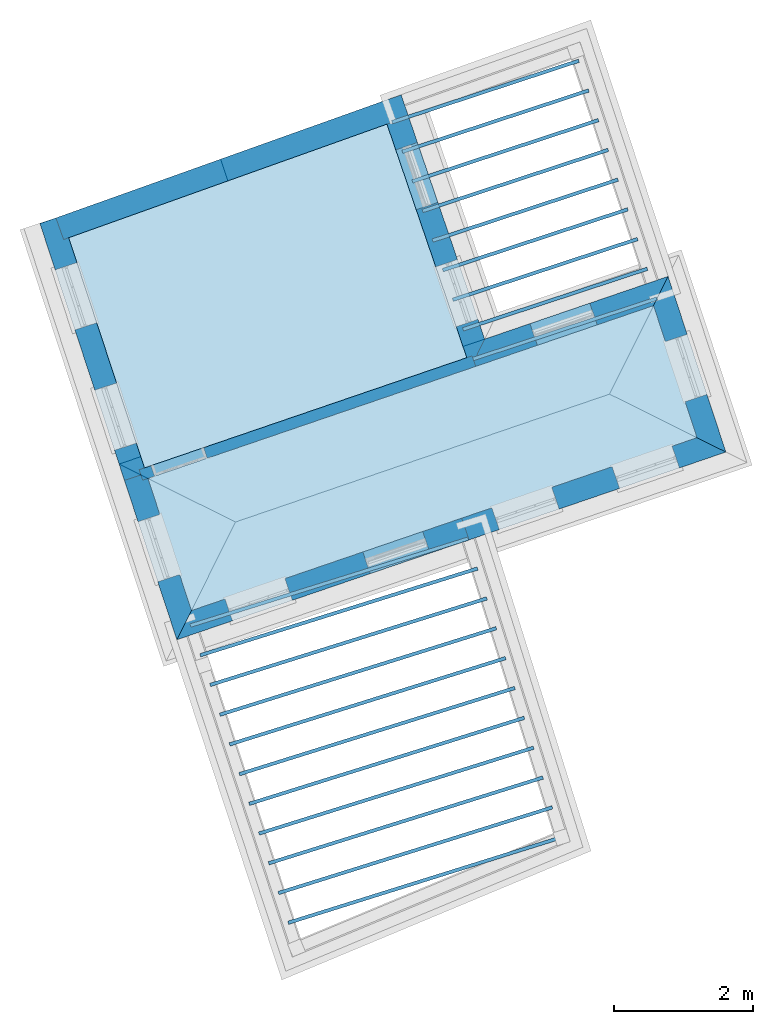
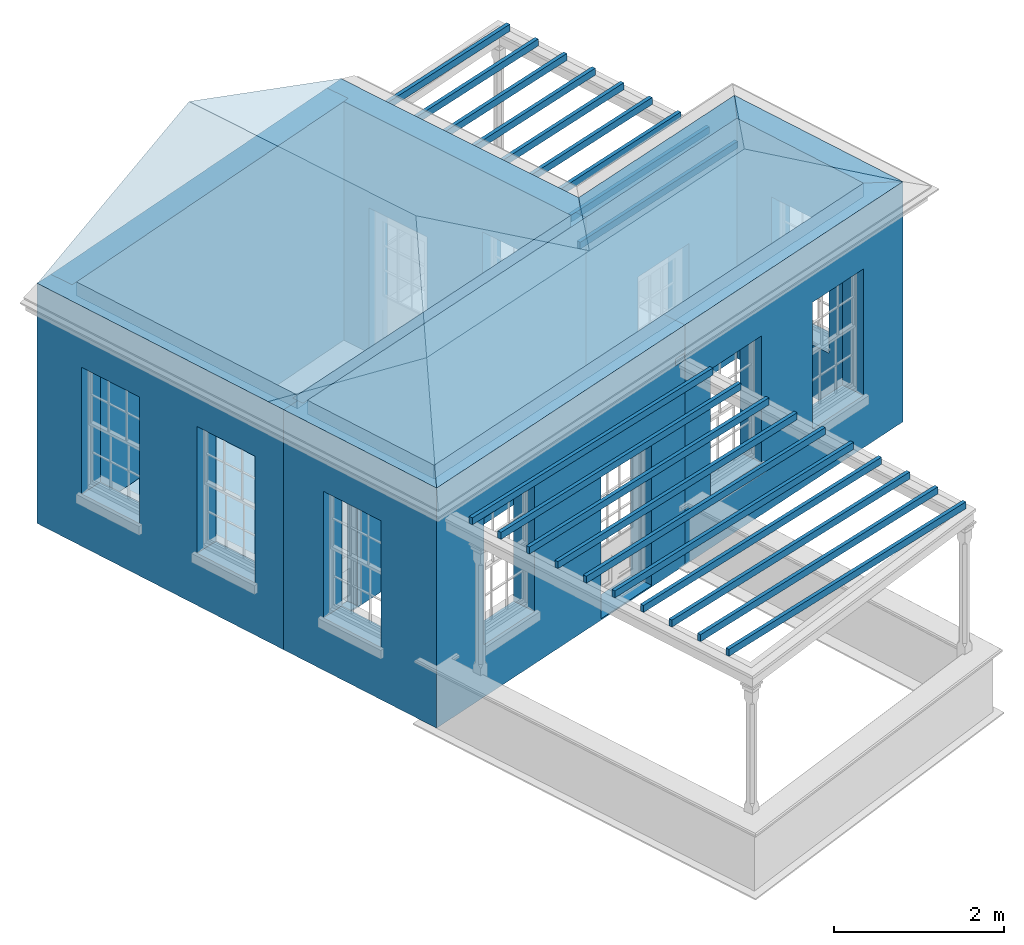
# One storey, part 1 of 10: 23 slabs, 9 walls, 2 roofs, 12 openings.
"""IFC2X3 building model written with IfcOpenShell, lengths in metres."""

from ifc_helpers import new_model, si_unit, frame, origin, place, context, subcontext, project, spatial, polyline, outline, extrude, faceted_brep, material, layer, layer_set, layer_usage, element, save


model = new_model("IFC2X3")

# Units and contexts
model_context = context("Model", 3, world=origin())
body_context = subcontext(model_context, "Body", "Model", "MODEL_VIEW")
ifc_project = project(units=[si_unit("PLANEANGLEUNIT", "RADIAN"), si_unit("MASSUNIT", "GRAM", prefix="KILO"), si_unit("FORCEUNIT", "NEWTON", prefix="KILO"), si_unit("LENGTHUNIT", "METRE")], contexts=[model_context])

# Site, building, storey
site_placement = place(None, origin())
site = spatial("IfcSite", under=ifc_project, at=site_placement, CompositionType="ELEMENT")
building_placement = place(None, origin())
building = spatial("IfcBuilding", under=site, at=building_placement, Name="Building plot-2", CompositionType="ELEMENT")
storey_placement = place(None, frame((0.0, 0.0, 8.2)))
storey = spatial("IfcBuildingStorey", under=building, at=storey_placement, Name="Floor 2", CompositionType="ELEMENT", Elevation=8.2)

# Slabs
slab_1_placement = place(storey_placement, frame((0.0, 0.0, 3.25)))
element("IfcSlab", 1, at=slab_1_placement, inside=storey, Name="Slab", ObjectType="Slab", PredefinedType="FLOOR", context=body_context, shape_type="SweptSolid", body=[
    extrude(outline(polyline([(28.7910712595401, 33.3262725875994), (29.4163238863492, 31.425692411646), (36.6893138301649, 33.9125007833851), (36.0640612033558, 35.8130809593384), (28.7910712595401, 33.3262725875994)])), origin(), (0.0, 0.0, 1.0), 0.2),
])
slab_2_placement = place(storey_placement, frame((0.0, 0.0, 2.95)))
element("IfcSlab", 2, at=slab_2_placement, inside=storey, Name="Slab", ObjectType="Slab", PredefinedType="FLOOR", context=body_context, shape_type="SweptSolid", body=[
    extrude(outline(polyline([(34.7490748976093, 28.1418547037494), (34.7341449250113, 28.189573629955), (30.8018548315201, 26.9592654899487), (30.8167848041181, 26.911546563743), (34.7490748976093, 28.1418547037494)])), origin(), (0.0, 0.0, 1.0), 0.1),
])
slab_3_placement = place(storey_placement, frame((0.0, 0.0, 2.95)))
element("IfcSlab", 3, at=slab_3_placement, inside=storey, Name="Slab", ObjectType="Slab", PredefinedType="FLOOR", context=body_context, shape_type="SweptSolid", body=[
    extrude(outline(polyline([(34.6147051442273, 28.5713250396005), (34.5997751716293, 28.6190439658061), (30.661213283939, 27.3867735495505), (30.676143256537, 27.3390546233448), (34.6147051442273, 28.5713250396005)])), origin(), (0.0, 0.0, 1.0), 0.1),
])
slab_4_placement = place(storey_placement, frame((0.0, 0.0, 2.95)))
element("IfcSlab", 4, at=slab_4_placement, inside=storey, Name="Slab", ObjectType="Slab", PredefinedType="FLOOR", context=body_context, shape_type="SweptSolid", body=[
    extrude(outline(polyline([(34.4803353908453, 29.0007953754516), (34.4654054182473, 29.0485143016572), (30.5205717363579, 27.8142816091524), (30.5355017089559, 27.7665626829467), (34.4803353908453, 29.0007953754516)])), origin(), (0.0, 0.0, 1.0), 0.1),
])
slab_5_placement = place(storey_placement, frame((0.0, 0.0, 2.95)))
element("IfcSlab", 5, at=slab_5_placement, inside=storey, Name="Slab", ObjectType="Slab", PredefinedType="FLOOR", context=body_context, shape_type="SweptSolid", body=[
    extrude(outline(polyline([(34.3459656374633, 29.4302657113027), (34.3310356648653, 29.4779846375084), (30.3799301887768, 28.2417896687542), (30.3948601613748, 28.1940707425485), (34.3459656374633, 29.4302657113027)])), origin(), (0.0, 0.0, 1.0), 0.1),
])
slab_6_placement = place(storey_placement, frame((0.0, 0.0, 2.95)))
element("IfcSlab", 6, at=slab_6_placement, inside=storey, Name="Slab", ObjectType="Slab", PredefinedType="FLOOR", context=body_context, shape_type="SweptSolid", body=[
    extrude(outline(polyline([(34.2115958840813, 29.8597360471538), (34.1966659114833, 29.9074549733595), (30.2392886411956, 28.6692977283561), (30.2542186137936, 28.6215788021504), (34.2115958840813, 29.8597360471538)])), origin(), (0.0, 0.0, 1.0), 0.1),
])
slab_7_placement = place(storey_placement, frame((0.0, 0.0, 2.95)))
element("IfcSlab", 7, at=slab_7_placement, inside=storey, Name="Slab", ObjectType="Slab", PredefinedType="FLOOR", context=body_context, shape_type="SweptSolid", body=[
    extrude(outline(polyline([(34.0772261306993, 30.2892063830049), (34.0622961581013, 30.3369253092106), (30.0986470936145, 29.0968057879579), (30.1135770662125, 29.0490868617523), (34.0772261306993, 30.2892063830049)])), origin(), (0.0, 0.0, 1.0), 0.1),
])
slab_8_placement = place(storey_placement, frame((0.0, 0.0, 2.95)))
element("IfcSlab", 8, at=slab_8_placement, inside=storey, Name="Slab", ObjectType="Slab", PredefinedType="FLOOR", context=body_context, shape_type="SweptSolid", body=[
    extrude(outline(polyline([(33.9428563773173, 30.718676718856), (33.9279264047193, 30.7663956450617), (29.9580055460334, 29.5243138475598), (29.9729355186314, 29.4765949213541), (33.9428563773173, 30.718676718856)])), origin(), (0.0, 0.0, 1.0), 0.1),
])
slab_9_placement = place(storey_placement, frame((0.0, 0.0, 2.95)))
element("IfcSlab", 9, at=slab_9_placement, inside=storey, Name="Slab", ObjectType="Slab", PredefinedType="FLOOR", context=body_context, shape_type="SweptSolid", body=[
    extrude(outline(polyline([(33.8084866239353, 31.1481470547071), (33.7935566513373, 31.1958659809128), (29.8173639984523, 29.9518219071616), (29.8322939710503, 29.904102980956), (33.8084866239353, 31.1481470547071)])), origin(), (0.0, 0.0, 1.0), 0.1),
])
slab_10_placement = place(storey_placement, frame((0.0, 0.0, 2.95)))
element("IfcSlab", 10, at=slab_10_placement, inside=storey, Name="Slab", ObjectType="Slab", PredefinedType="FLOOR", context=body_context, shape_type="SweptSolid", body=[
    extrude(outline(polyline([(33.6741168705533, 31.5776173905582), (33.6591868979553, 31.6253363167639), (29.6767224508711, 30.3793299667635), (29.6916524234691, 30.3316110405578), (33.6741168705533, 31.5776173905582)])), origin(), (0.0, 0.0, 1.0), 0.1),
])
slab_11_placement = place(storey_placement, frame((0.0, 0.0, 2.95)))
element("IfcSlab", 11, at=slab_11_placement, inside=storey, Name="Slab", ObjectType="Slab", PredefinedType="FLOOR", context=body_context, shape_type="SweptSolid", body=[
    extrude(outline(polyline([(33.5397471171713, 32.0070877264093), (33.5248171445733, 32.054806652615), (29.53608090329, 30.8068380263653), (29.551010875888, 30.7591191001597), (33.5397471171713, 32.0070877264093)])), origin(), (0.0, 0.0, 1.0), 0.1),
])
slab_12_placement = place(storey_placement, frame((0.0, 0.0, 2.95)))
element("IfcSlab", 12, at=slab_12_placement, inside=storey, Name="Slab", ObjectType="Slab", PredefinedType="FLOOR", context=body_context, shape_type="SweptSolid", body=[
    extrude(outline(polyline([(33.4053773637893, 32.4365580622604), (33.3904473911913, 32.4842769884661), (29.3954393557089, 31.2343460859672), (29.4103693283069, 31.1866271597615), (33.4053773637893, 32.4365580622604)])), origin(), (0.0, 0.0, 1.0), 0.1),
])
slab_13_placement = place(storey_placement, frame((0.0, 0.0, 2.95)))
element("IfcSlab", 13, at=slab_13_placement, inside=storey, Name="Slab", ObjectType="Slab", PredefinedType="FLOOR", context=body_context, shape_type="SweptSolid", body=[
    extrude(outline(polyline([(36.1225742696594, 35.8912159862699), (36.1069490970928, 35.9387118174791), (33.460924460916, 35.068222966073), (33.4765496334827, 35.0207271348637), (36.1225742696594, 35.8912159862699)])), origin(), (0.0, 0.0, 1.0), 0.1),
])
slab_14_placement = place(storey_placement, frame((0.0, 0.0, 2.95)))
element("IfcSlab", 14, at=slab_14_placement, inside=storey, Name="Slab", ObjectType="Slab", PredefinedType="FLOOR", context=body_context, shape_type="SweptSolid", body=[
    extrude(outline(polyline([(35.9819477165593, 36.3186784671535), (35.9663225439926, 36.3661742983628), (33.3153243232244, 35.4940492377244), (33.3309494957911, 35.4465534065151), (35.9819477165593, 36.3186784671535)])), origin(), (0.0, 0.0, 1.0), 0.1),
])
slab_15_placement = place(storey_placement, frame((0.0, 0.0, 2.95)))
element("IfcSlab", 15, at=slab_15_placement, inside=storey, Name="Slab", ObjectType="Slab", PredefinedType="FLOOR", context=body_context, shape_type="SweptSolid", body=[
    extrude(outline(polyline([(35.8413211634592, 36.7461409480371), (35.8256959908925, 36.7936367792464), (33.1697241855328, 35.9198755093758), (33.1853493580995, 35.8723796781665), (35.8413211634592, 36.7461409480371)])), origin(), (0.0, 0.0, 1.0), 0.1),
])
slab_16_placement = place(storey_placement, frame((0.0, 0.0, 2.95)))
element("IfcSlab", 16, at=slab_16_placement, inside=storey, Name="Slab", ObjectType="Slab", PredefinedType="FLOOR", context=body_context, shape_type="SweptSolid", body=[
    extrude(outline(polyline([(35.700694610359, 37.1736034289207), (35.6850694377923, 37.22109926013), (33.0241240478412, 36.3457017810272), (33.0397492204079, 36.2982059498179), (35.700694610359, 37.1736034289207)])), origin(), (0.0, 0.0, 1.0), 0.1),
])
slab_17_placement = place(storey_placement, frame((0.0, 0.0, 2.95)))
element("IfcSlab", 17, at=slab_17_placement, inside=storey, Name="Slab", ObjectType="Slab", PredefinedType="FLOOR", context=body_context, shape_type="SweptSolid", body=[
    extrude(outline(polyline([(35.5600680572589, 37.6010659098043), (35.5444428846922, 37.6485617410136), (32.8785239101496, 36.7715280526786), (32.8941490827163, 36.7240322214693), (35.5600680572589, 37.6010659098043)])), origin(), (0.0, 0.0, 1.0), 0.1),
])
slab_18_placement = place(storey_placement, frame((0.0, 0.0, 2.95)))
element("IfcSlab", 18, at=slab_18_placement, inside=storey, Name="Slab", ObjectType="Slab", PredefinedType="FLOOR", context=body_context, shape_type="SweptSolid", body=[
    extrude(outline(polyline([(35.4194415041587, 38.0285283906879), (35.403816331592, 38.0760242218972), (32.732923772458, 37.19735432433), (32.7485489450247, 37.1498584931207), (35.4194415041587, 38.0285283906879)])), origin(), (0.0, 0.0, 1.0), 0.1),
])
slab_19_placement = place(storey_placement, frame((0.0, 0.0, 2.95)))
element("IfcSlab", 19, at=slab_19_placement, inside=storey, Name="Slab", ObjectType="Slab", PredefinedType="FLOOR", context=body_context, shape_type="SweptSolid", body=[
    extrude(outline(polyline([(35.2788149510586, 38.4559908715715), (35.2631897784919, 38.5034867027808), (32.5873236347664, 37.6231805959814), (32.6029488073331, 37.5756847647721), (35.2788149510586, 38.4559908715715)])), origin(), (0.0, 0.0, 1.0), 0.1),
])
slab_20_placement = place(storey_placement, frame((0.0, 0.0, 2.95)))
element("IfcSlab", 20, at=slab_20_placement, inside=storey, Name="Slab", ObjectType="Slab", PredefinedType="FLOOR", context=body_context, shape_type="SweptSolid", body=[
    extrude(outline(polyline([(35.1381883979584, 38.8834533524551), (35.1225632253918, 38.9309491836644), (32.4417234970749, 38.0490068676328), (32.4573486696415, 38.0015110364235), (35.1381883979584, 38.8834533524551)])), origin(), (0.0, 0.0, 1.0), 0.1),
])
slab_21_placement = place(storey_placement, frame((0.0, 0.0, 2.95)))
element("IfcSlab", 21, at=slab_21_placement, inside=storey, Name="Slab", ObjectType="Slab", PredefinedType="FLOOR", context=body_context, shape_type="SweptSolid", body=[
    extrude(outline(polyline([(34.9975618448583, 39.3109158333388), (34.9819366722916, 39.358411664548), (32.2961233593833, 38.4748331392842), (32.31174853195, 38.4273373080749), (34.9975618448583, 39.3109158333388)])), origin(), (0.0, 0.0, 1.0), 0.1),
])
slab_22_placement = place(storey_placement, frame((0.0, 0.0, 3.25)))
element("IfcSlab", 22, at=slab_22_placement, inside=storey, Name="Slab", ObjectType="Slab", PredefinedType="FLOOR", context=body_context, shape_type="SweptSolid", body=[
    extrude(outline(polyline([(28.7410673229935, 33.4782695348257), (33.3776420525997, 35.0636247935088), (32.2290020264794, 38.4229698294896), (27.6518880966078, 36.7890472220676), (28.7410673229935, 33.4782695348257)])), origin(), (0.0, 0.0, 1.0), 0.2),
])
slab_23_placement = place(storey_placement, origin())
element("IfcSlab", 23, at=slab_23_placement, inside=storey, Name="Slab", ObjectType="Slab", PredefinedType="FLOOR", context=body_context, shape_type="SweptSolid", body=[
    extrude(outline(polyline([(28.7410673229935, 33.4782695348257), (33.3776420525997, 35.0636247935088), (32.2290020264794, 38.4229698294896), (27.6518880966078, 36.7890472220676), (28.7410673229935, 33.4782695348257)])), origin(), (0.0, 0.0, 1.0), 0.02),
])

# Wall, openings
ifc_material_1 = material(Name="Masonry")
ifc_layer_1 = layer(ifc_material_1, 0.33, ventilated=False)
ifc_layer_set_1 = layer_set([ifc_layer_1], Name="My Wall")
ifc_layer_usage_1 = layer_usage(ifc_layer_set_1, "AXIS2", "NEGATIVE", 0.08)
wall_1_placement = place(storey_placement, origin())
wall_1 = element("IfcWallStandardCase", 24, at=wall_1_placement, inside=storey, material=ifc_layer_usage_1, Name="exterior", context=body_context, shape_type="SweptSolid", body=[
    extrude(outline(polyline([(27.5493804790374, 37.1006395888727), (27.2359079930561, 36.9975134499325), (28.4528876869268, 33.2982607294562), (28.7663601729081, 33.4013868683963), (27.5493804790374, 37.1006395888727)])), origin(), (0.0, 0.0, 1.0), 3.45),
])
opening_1_placement = place(storey_placement, frame((0.0, 0.0, 0.75)))
element("IfcOpeningElement", 25, at=opening_1_placement, cuts=wall_1, Name="Opening", ObjectType="Opening", context=body_context, shape_type="SweptSolid", body=[
    extrude(outline(polyline([(27.456558243292, 36.3268029667832), (27.7409363840057, 35.4623788387741), (28.054408869987, 35.5655049777142), (27.7700307292734, 36.4299291057233), (27.456558243292, 36.3268029667832)])), origin(), (0.0, 0.0, 1.0), 1.82),
])
opening_2_placement = place(storey_placement, frame((0.0, 0.0, 0.75)))
element("IfcOpeningElement", 26, at=opening_2_placement, cuts=wall_1, Name="Opening", ObjectType="Opening", context=body_context, shape_type="SweptSolid", body=[
    extrude(outline(polyline([(28.0259851588106, 34.5959161845682), (28.3103632995243, 33.7314920565591), (28.6238357855056, 33.8346181954992), (28.339457644792, 34.6990423235083), (28.0259851588106, 34.5959161845682)])), origin(), (0.0, 0.0, 1.0), 1.82),
])

# Wall, opening
wall_2_placement = place(storey_placement, origin())
wall_2 = element("IfcWallStandardCase", 27, at=wall_2_placement, inside=storey, material=ifc_layer_usage_1, Name="exterior", context=body_context, shape_type="SweptSolid", body=[
    extrude(outline(polyline([(28.7663601729081, 33.4013868683963), (28.4528876869268, 33.2982607294562), (29.2071844062656, 31.0054252736847), (29.4163238863492, 31.425692411646), (28.7663601729081, 33.4013868683963)])), origin(), (0.0, 0.0, 1.0), 3.45),
])
opening_3_placement = place(storey_placement, frame((0.0, 0.0, 0.75)))
element("IfcOpeningElement", 28, at=opening_3_placement, cuts=wall_2, Name="Opening", ObjectType="Opening", context=body_context, shape_type="SweptSolid", body=[
    extrude(outline(polyline([(28.6483268982478, 32.7041842318709), (28.9327050389614, 31.8397601038618), (29.2461775249427, 31.9428862428019), (28.9617993842291, 32.807310370811), (28.6483268982478, 32.7041842318709)])), origin(), (0.0, 0.0, 1.0), 1.82),
])

# Wall, openings
wall_3_placement = place(storey_placement, origin())
wall_3 = element("IfcWallStandardCase", 29, at=wall_3_placement, inside=storey, material=ifc_layer_usage_1, Name="exterior", context=body_context, shape_type="SweptSolid", body=[
    extrude(outline(polyline([(29.4163238863492, 31.425692411646), (29.2071844062656, 31.0054252736847), (33.4103616674271, 32.4425916222849), (33.3035954596887, 32.7548430864691), (29.4163238863492, 31.425692411646)])), origin(), (0.0, 0.0, 1.0), 3.45),
])
opening_4_placement = place(storey_placement, frame((0.0, 0.0, 0.75)))
element("IfcOpeningElement", 30, at=opening_4_placement, cuts=wall_3, Name="Opening", ObjectType="Opening", context=body_context, shape_type="SweptSolid", body=[
    extrude(outline(polyline([(30.0069420556858, 31.2788814496597), (30.8679991235876, 31.5732973558475), (30.7612329158491, 31.8855488200316), (29.9001758479473, 31.5911329138438), (30.0069420556858, 31.2788814496597)])), origin(), (0.0, 0.0, 1.0), 1.82),
])
opening_5_placement = place(storey_placement, frame((0.0, 0.0, 0.0199999999999996)))
element("IfcOpeningElement", 31, at=opening_5_placement, cuts=wall_3, Name="Opening", ObjectType="Opening", context=body_context, shape_type="SweptSolid", body=[
    extrude(outline(polyline([(31.9888694408794, 31.9565495960139), (32.8499265087812, 32.2509655022017), (32.7431603010428, 32.5632169663859), (31.882103233141, 32.2688010601981), (31.9888694408794, 31.9565495960139)])), origin(), (0.0, 0.0, 1.0), 2.08),
])

wall_4_placement = place(storey_placement, origin())
wall_4 = element("IfcWallStandardCase", 32, at=wall_4_placement, inside=storey, material=ifc_layer_usage_1, Name="exterior", context=body_context, shape_type="SweptSolid", body=[
    extrude(outline(polyline([(33.3035954596887, 32.7548430864691), (33.4103616674271, 32.4425916222849), (37.1047195485034, 33.7057805140381), (36.6893138301649, 33.9125007833851), (33.3035954596887, 32.7548430864691)])), origin(), (0.0, 0.0, 1.0), 3.45),
])
opening_6_placement = place(storey_placement, frame((0.0, 0.0, 0.75)))
element("IfcOpeningElement", 33, at=opening_6_placement, cuts=wall_4, Name="Opening", ObjectType="Opening", context=body_context, shape_type="SweptSolid", body=[
    extrude(outline(polyline([(33.8449681509801, 32.5911939234102), (34.7060252188819, 32.885609829598), (34.5992590111435, 33.1978612937821), (33.7382019432417, 32.9034453875943), (33.8449681509801, 32.5911939234102)])), origin(), (0.0, 0.0, 1.0), 1.82),
])
opening_7_placement = place(storey_placement, frame((0.0, 0.0, 0.75)))
element("IfcOpeningElement", 34, at=opening_7_placement, cuts=wall_4, Name="Opening", ObjectType="Opening", context=body_context, shape_type="SweptSolid", body=[
    extrude(outline(polyline([(35.5752381859879, 33.1828144318484), (36.4362952538897, 33.4772303380362), (36.3295290461513, 33.7894818022204), (35.4684719782495, 33.4950658960326), (35.5752381859879, 33.1828144318484)])), origin(), (0.0, 0.0, 1.0), 1.82),
])

# Wall, opening
wall_5_placement = place(storey_placement, origin())
wall_5 = element("IfcWallStandardCase", 35, at=wall_5_placement, inside=storey, material=ifc_layer_usage_1, Name="exterior", context=body_context, shape_type="SweptSolid", body=[
    extrude(outline(polyline([(36.6893138301649, 33.9125007833851), (37.1047195485034, 33.7057805140381), (36.2732006834394, 36.2333480972997), (36.0640612033558, 35.8130809593384), (36.6893138301649, 33.9125007833851)])), origin(), (0.0, 0.0, 1.0), 3.45),
])
opening_8_placement = place(storey_placement, frame((0.0, 0.0, 0.75)))
element("IfcOpeningElement", 36, at=opening_8_placement, cuts=wall_5, Name="Opening", ObjectType="Opening", context=body_context, shape_type="SweptSolid", body=[
    extrude(outline(polyline([(36.8320581914572, 34.5345891391136), (36.5476800507436, 35.3990132671227), (36.2342075647623, 35.2958871281825), (36.5185857054759, 34.4314630001735), (36.8320581914572, 34.5345891391136)])), origin(), (0.0, 0.0, 1.0), 1.82),
])

wall_6_placement = place(storey_placement, origin())
wall_6 = element("IfcWallStandardCase", 37, at=wall_6_placement, inside=storey, material=ifc_layer_usage_1, Name="exterior", context=body_context, shape_type="SweptSolid", body=[
    extrude(outline(polyline([(36.0640612033558, 35.8130809593384), (36.2732006834394, 36.2333480972997), (33.6348927431004, 35.33124781613), (33.4294074866547, 34.9122301442074), (36.0640612033558, 35.8130809593384)])), origin(), (0.0, 0.0, 1.0), 3.45),
])
opening_9_placement = place(storey_placement, frame((0.0, 0.0, 0.0199999999999996)))
element("IfcOpeningElement", 38, at=opening_9_placement, cuts=wall_6, Name="Opening", ObjectType="Opening", context=body_context, shape_type="SweptSolid", body=[
    extrude(outline(polyline([(35.146636932067, 35.8481491365074), (34.2855798641652, 35.5537332303196), (34.3923460719036, 35.2414817661354), (35.2534031398054, 35.5358976723233), (35.146636932067, 35.8481491365074)])), origin(), (0.0, 0.0, 1.0), 2.08),
])

# Wall, openings
wall_7_placement = place(storey_placement, origin())
wall_7 = element("IfcWallStandardCase", 39, at=wall_7_placement, inside=storey, material=ifc_layer_usage_1, Name="exterior", context=body_context, shape_type="SweptSolid", body=[
    extrude(outline(polyline([(33.4294074866547, 34.9122301442074), (33.6348927431004, 35.33124781613), (32.4341377283562, 38.8430098185691), (32.1218862641721, 38.7362436108307), (33.4294074866547, 34.9122301442074)])), origin(), (0.0, 0.0, 1.0), 3.45),
])
opening_10_placement = place(storey_placement, frame((0.0, 0.0, 0.75)))
element("IfcOpeningElement", 40, at=opening_10_placement, cuts=wall_7, Name="Opening", ObjectType="Opening", context=body_context, shape_type="SweptSolid", body=[
    extrude(outline(polyline([(33.5378325542473, 35.6151127835701), (33.2434166480595, 36.4761698514719), (32.9311651838753, 36.3694036437335), (33.2255810900631, 35.5083465758317), (33.5378325542473, 35.6151127835701)])), origin(), (0.0, 0.0, 1.0), 1.82),
])
opening_11_placement = place(storey_placement, frame((0.0, 0.0, 0.0199999999999996)))
element("IfcOpeningElement", 41, at=opening_11_placement, cuts=wall_7, Name="Opening", ObjectType="Opening", context=body_context, shape_type="SweptSolid", body=[
    extrude(outline(polyline([(32.9624179258471, 37.297986644475), (32.6680020196593, 38.1590437123768), (32.3557505554751, 38.0522775046383), (32.6501664616629, 37.1912204367365), (32.9624179258471, 37.297986644475)])), origin(), (0.0, 0.0, 1.0), 2.08),
])

# Wall
wall_8_placement = place(storey_placement, origin())
element("IfcWallStandardCase", 42, at=wall_8_placement, inside=storey, material=ifc_layer_usage_1, Name="party", context=body_context, shape_type="SweptSolid", body=[
    extrude(outline(polyline([(32.3053628822139, 38.4502288687921), (32.1944176961582, 38.761020061864), (27.4674636285605, 37.0736080302588), (27.5784088146162, 36.7628168371869), (32.3053628822139, 38.4502288687921)])), origin(), (0.0, 0.0, 1.0), 3.45),
])

# Wall, opening
ifc_material_2 = material(Name="Masonry")
ifc_layer_2 = layer(ifc_material_2, 0.16, ventilated=False)
ifc_layer_set_2 = layer_set([ifc_layer_2], Name="My Wall")
ifc_layer_usage_2 = layer_usage(ifc_layer_set_2, "AXIS2", "NEGATIVE", 0.08)
wall_9_placement = place(storey_placement, origin())
wall_9 = element("IfcWallStandardCase", 43, at=wall_9_placement, inside=storey, material=ifc_layer_usage_2, Name="interior", context=body_context, shape_type="SweptSolid", body=[
    extrude(outline(polyline([(33.5051048113054, 34.9381128612349), (33.4533393772504, 35.0895075105363), (28.6644841259457, 33.4520839169403), (28.7162495600007, 33.3006892676389), (33.5051048113054, 34.9381128612349)])), origin(), (0.0, 0.0, 1.0), 3.45),
])
opening_12_placement = place(storey_placement, frame((0.0, 0.0, 0.0199999999999996)))
element("IfcOpeningElement", 44, at=opening_12_placement, cuts=wall_9, Name="Opening", ObjectType="Opening", context=body_context, shape_type="SweptSolid", body=[
    extrude(outline(polyline([(29.5917763529169, 33.7691472005271), (28.8348031064098, 33.5103200302522), (28.8865685404648, 33.3589253809508), (29.6435417869719, 33.6177525512257), (29.5917763529169, 33.7691472005271)])), origin(), (0.0, 0.0, 1.0), 2.1),
])

# Roofs
roof_1_placement = place(building_placement, origin())
element("IfcRoof", 45, at=roof_1_placement, inside=storey, Name="Roof", ShapeType="FREEFORM", context=body_context, shape_type="Brep", held_by="IfcProductRepresentation", body=[
    faceted_brep([(34.495704, 32.813696, 11.65), (32.433045, 38.846205, 11.65), (29.835734, 37.919025, 12.792233), (30.967951, 34.543697, 12.800811), (27.237841, 36.991638, 11.65), (29.207184, 31.005425, 11.65)], [[[0, 1, 2, 3]], [[4, 5, 3, 2]], [[5, 4, 1, 0]], [[5, 0, 3]], [[1, 4, 2]]]),
])
roof_2_placement = place(building_placement, origin())
element("IfcRoof", 46, at=roof_2_placement, inside=storey, Name="Roof", ShapeType="FREEFORM", context=body_context, shape_type="Brep", held_by="IfcProductRepresentation", body=[
    faceted_brep([(29.207184, 31.005425, 11.65), (37.10472, 33.705781, 11.65), (35.430099, 34.53913, 12.201039), (30.050286, 32.699644, 12.201039), (36.273201, 36.233348, 11.65), (28.375666, 33.532993, 11.65)], [[[0, 1, 2, 3]], [[4, 5, 3, 2]], [[5, 4, 1, 0]], [[5, 0, 3]], [[1, 4, 2]]]),
])

save(model, "model.ifc")
